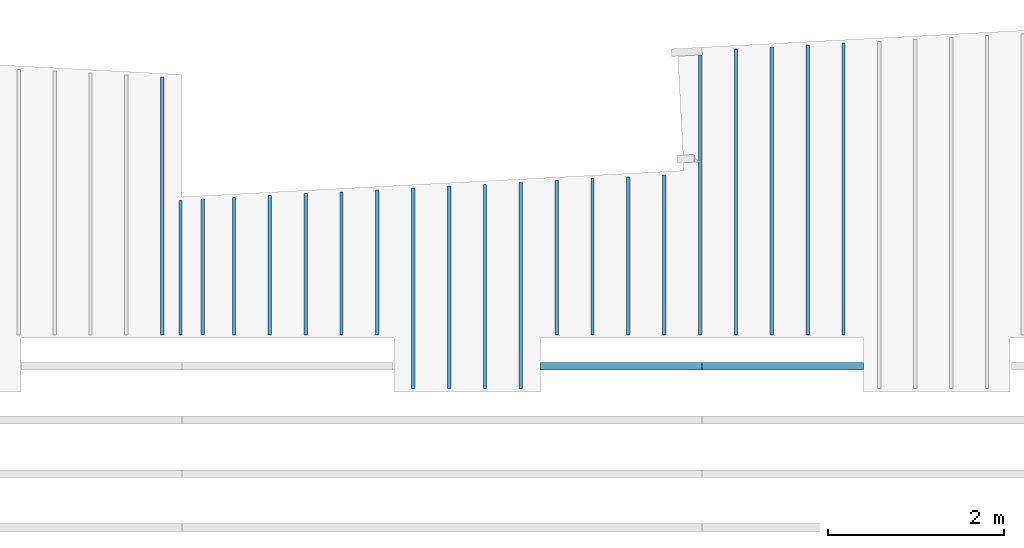
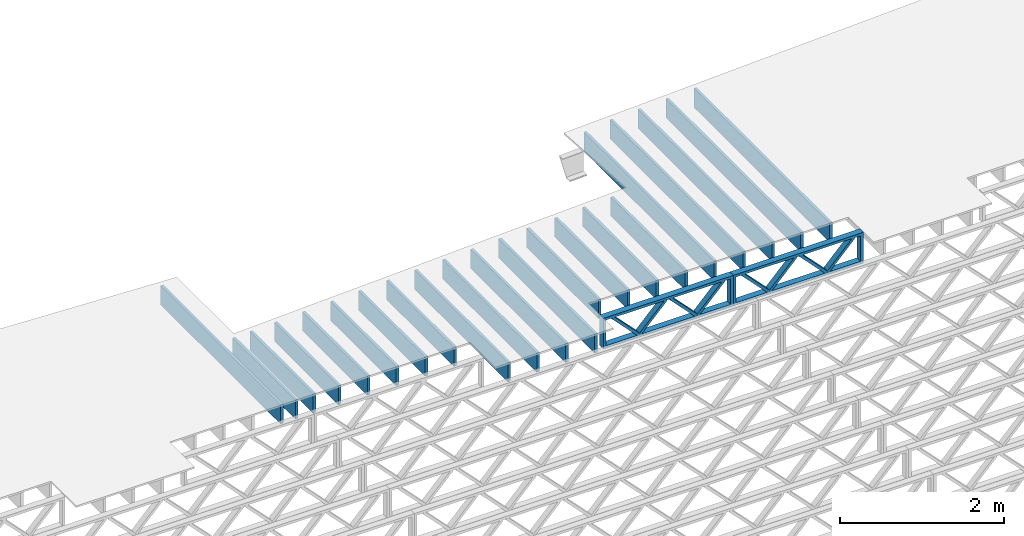
# One storey, part 5 of 12: 23 beams, 3 elements without a shape of their own.
"""IFC4 building model written with IfcOpenShell, lengths in feet."""

from ifc_helpers import new_model, entity, si_unit, converted_unit, derived_unit, direction, frame, frame_2d, origin, origin_2d_with_axis, place, context, subcontext, project, spatial, rectangle, extrude, source, transform, mapped, material, material_profile, profile_set, profile_usage, type_object, type_shapes, element, aggregate, save


model = new_model("IFC4")

# Units and contexts
model_context = context("Model", 3, precision=0.0001, world=origin(), true_north=direction((6.12303176911189e-17, 1.0)))
body_context = subcontext(model_context, "Body", "Model", "MODEL_VIEW")
ifc_project = project(units=[converted_unit("LENGTHUNIT", "FOOT", entity("IfcRatioMeasure", 0.3048), si_unit("LENGTHUNIT", "METRE"), dimensions=[1, 0, 0, 0, 0, 0, 0]), converted_unit("AREAUNIT", "SQUARE FOOT", entity("IfcRatioMeasure", 0.09290304), si_unit("AREAUNIT", "SQUARE_METRE"), dimensions=[2, 0, 0, 0, 0, 0, 0]), converted_unit("VOLUMEUNIT", "CUBIC FOOT", entity("IfcRatioMeasure", 0.028316846592), si_unit("VOLUMEUNIT", "CUBIC_METRE"), dimensions=[3, 0, 0, 0, 0, 0, 0]), converted_unit("PLANEANGLEUNIT", "DEGREE", entity("IfcRatioMeasure", 0.0174532925199433), si_unit("PLANEANGLEUNIT", "RADIAN"), dimensions=[0, 0, 0, 0, 0, 0, 0]), si_unit("MASSUNIT", "GRAM", prefix="KILO"), derived_unit("MASSDENSITYUNIT", [(si_unit("MASSUNIT", "GRAM", prefix="KILO"), 1), (si_unit("LENGTHUNIT", "METRE"), -3)]), derived_unit("MOMENTOFINERTIAUNIT", [(si_unit("LENGTHUNIT", "METRE"), 4)]), si_unit("TIMEUNIT", "SECOND"), si_unit("FREQUENCYUNIT", "HERTZ"), si_unit("THERMODYNAMICTEMPERATUREUNIT", "DEGREE_CELSIUS"), derived_unit("THERMALTRANSMITTANCEUNIT", [(si_unit("MASSUNIT", "GRAM", prefix="KILO"), 1), (si_unit("THERMODYNAMICTEMPERATUREUNIT", "KELVIN"), -1), (si_unit("TIMEUNIT", "SECOND"), -3)]), derived_unit("VOLUMETRICFLOWRATEUNIT", [(si_unit("LENGTHUNIT", "METRE"), 3), (si_unit("TIMEUNIT", "SECOND"), -1)]), si_unit("ELECTRICCURRENTUNIT", "AMPERE"), si_unit("ELECTRICVOLTAGEUNIT", "VOLT"), si_unit("POWERUNIT", "WATT"), si_unit("FORCEUNIT", "NEWTON"), si_unit("ILLUMINANCEUNIT", "LUX"), si_unit("LUMINOUSFLUXUNIT", "LUMEN"), si_unit("LUMINOUSINTENSITYUNIT", "CANDELA"), derived_unit("USERDEFINED", [(si_unit("MASSUNIT", "GRAM", prefix="KILO"), -1), (si_unit("LENGTHUNIT", "METRE"), -2), (si_unit("TIMEUNIT", "SECOND"), 3), (si_unit("LUMINOUSFLUXUNIT", "LUMEN"), 1)]), derived_unit("LINEARVELOCITYUNIT", [(si_unit("LENGTHUNIT", "METRE"), 1), (si_unit("TIMEUNIT", "SECOND"), -1)]), si_unit("PRESSUREUNIT", "PASCAL"), derived_unit("USERDEFINED", [(si_unit("LENGTHUNIT", "METRE"), -2), (si_unit("MASSUNIT", "GRAM", prefix="KILO"), 1), (si_unit("TIMEUNIT", "SECOND"), -2)]), derived_unit("LINEARFORCEUNIT", [(si_unit("MASSUNIT", "GRAM", prefix="KILO"), 1), (si_unit("LENGTHUNIT", "METRE"), 1), (si_unit("TIMEUNIT", "SECOND"), -2), (si_unit("LENGTHUNIT", "METRE"), -1)]), derived_unit("PLANARFORCEUNIT", [(si_unit("MASSUNIT", "GRAM", prefix="KILO"), 1), (si_unit("LENGTHUNIT", "METRE"), 1), (si_unit("TIMEUNIT", "SECOND"), -2), (si_unit("LENGTHUNIT", "METRE"), -2)])], contexts=[model_context])

# Site, building, storey
site_placement = place(None, origin())
site = spatial("IfcSite", under=ifc_project, at=site_placement, CompositionType="ELEMENT")
building_placement = place(site_placement, origin())
building = spatial("IfcBuilding", under=site, at=building_placement, CompositionType="ELEMENT")
storey_placement = place(building_placement, frame((0.0, 0.0, 21.46875)))
storey = spatial("IfcBuildingStorey", under=building, at=storey_placement, Name="3RD FLOOR", CompositionType="ELEMENT", Elevation=21.46875)

# Assembly, beam
assembly_1_placement = place(storey_placement, origin())
assembly_1 = element("IfcElementAssembly", 1, at=assembly_1_placement, inside=storey, Name="Structural Beam System:Structural Framing System", ObjectType="Structural Beam System:Structural Framing System", AssemblyPlace="NOTDEFINED", PredefinedType="BEAM_GRID")
ifc_material_1 = material(Name="WOOD TRUSS", Category="Materials")
ifc_material_profile_1 = material_profile(ifc_material_1, rectangle(XDim=1.73473973950632, YDim=0.125, at=frame_2d((-1.11022302462516e-16, 8.32667268468867e-17), x_axis=(1.0, 0.0))))
ifc_material_profile_2 = material_profile(ifc_material_1, rectangle(XDim=1.73473973950633, YDim=0.125, at=frame_2d((-1.11022302462516e-16, 8.32667268468867e-17), x_axis=(1.0, 0.0))))
ifc_material_profile_3 = material_profile(ifc_material_1, rectangle(XDim=1.73473973950632, YDim=0.125, at=frame_2d((-5.55111512312578e-17, 1.38777878078145e-16), x_axis=(1.0, 0.0))))
ifc_material_profile_4 = material_profile(ifc_material_1, rectangle(XDim=1.73473973950633, YDim=0.125, at=frame_2d((-1.11022302462516e-16, 8.32667268468867e-17), x_axis=(1.0, 0.0))))
ifc_material_profile_5 = material_profile(ifc_material_1, rectangle(XDim=1.73473973950632, YDim=0.125, at=frame_2d((-1.11022302462516e-16, 8.32667268468867e-17), x_axis=(1.0, 0.0))))
ifc_material_profile_6 = material_profile(ifc_material_1, rectangle(XDim=1.73473973950633, YDim=0.125, at=frame_2d((-2.77555756156289e-16, 3.05311331771918e-16), x_axis=(1.0, 0.0))))
ifc_material_profile_7 = material_profile(ifc_material_1, rectangle(XDim=1.73473973950632, YDim=0.124999999999999, at=frame_2d((-3.88578058618805e-16, -2.4980018054066e-16), x_axis=(1.0, 0.0))))
ifc_material_profile_8 = material_profile(ifc_material_1, rectangle(XDim=1.73473973950633, YDim=0.125, at=frame_2d((2.77555756156289e-16, -3.05311331771918e-16), x_axis=(1.0, 0.0))))
ifc_material_profile_9 = material_profile(ifc_material_1, rectangle(XDim=1.73473973950632, YDim=0.124999999999999, at=frame_2d((-1.11022302462516e-16, 8.32667268468867e-17), x_axis=(1.0, 0.0))))
ifc_material_profile_10 = material_profile(ifc_material_1, rectangle(XDim=1.73473973950633, YDim=0.125, at=origin_2d_with_axis()))
ifc_material_profile_11 = material_profile(ifc_material_1, rectangle(XDim=0.124999999999982, YDim=0.291666666666668, at=origin_2d_with_axis()))
ifc_material_profile_12 = material_profile(ifc_material_1, rectangle(XDim=0.124999999999932, YDim=0.291666666666664, at=origin_2d_with_axis()))
ifc_material_profile_13 = material_profile(ifc_material_1, rectangle(XDim=1.25000000000002, YDim=0.29166666666667, at=origin_2d_with_axis()))
ifc_material_profile_14 = material_profile(ifc_material_1, rectangle(XDim=1.25000000000004, YDim=0.291666666666667, at=origin_2d_with_axis()))
ifc_profile_set_1 = profile_set([ifc_material_profile_1, ifc_material_profile_2, ifc_material_profile_3, ifc_material_profile_4, ifc_material_profile_5, ifc_material_profile_6, ifc_material_profile_7, ifc_material_profile_8, ifc_material_profile_9, ifc_material_profile_10, ifc_material_profile_11, ifc_material_profile_12, ifc_material_profile_13, ifc_material_profile_14])
ifc_profile_usage_1 = profile_usage(ifc_profile_set_1, cardinal=8)
beam_type_1 = type_object("IfcBeamType", PredefinedType="BEAM", material=ifc_profile_set_1)
shared_shape_1 = source(origin(), body_context, "Body", "SweptSolid", [
    extrude(rectangle(XDim=1.73473973950632, YDim=0.125, at=frame_2d((0.0, 1.66533453693773e-16), x_axis=(1.0, 0.0))), frame((1.95847612494153, -0.145833333333334, 0.0), z_axis=(0.0, 1.0, 0.0), x_axis=(0.693383046997606, 0.0, 0.720569184836762)), (0.0, 0.0, 1.0), 0.291666666666667),
    extrude(rectangle(XDim=1.73473973950633, YDim=0.125, at=frame_2d((-5.55111512312578e-17, 8.32667268468867e-17), x_axis=(1.0, 0.0))), frame((0.708190251268258, -0.145833333333334, 0.0), z_axis=(0.0, 1.0, 0.0), x_axis=(0.69338304699761, 0.0, -0.720569184836758)), (0.0, 0.0, 1.0), 0.291666666666667),
    extrude(rectangle(XDim=1.73473973950632, YDim=0.125, at=frame_2d((0.0, 1.66533453693773e-16), x_axis=(1.0, 0.0))), frame((-0.708190251267602, -0.145833333333334, 0.0), z_axis=(0.0, 1.0, 0.0), x_axis=(0.693383046997606, 0.0, 0.720569184836762)), (0.0, 0.0, 1.0), 0.291666666666667),
    extrude(rectangle(XDim=1.73473973950633, YDim=0.125, at=frame_2d((-2.22044604925031e-16, 2.22044604925031e-16), x_axis=(1.0, 0.0))), frame((-1.95847612494087, -0.145833333333334, 0.0), z_axis=(0.0, 1.0, 0.0), x_axis=(0.69338304699761, 0.0, -0.720569184836758)), (0.0, 0.0, 1.0), 0.291666666666666),
    extrude(rectangle(XDim=0.124999999999982, YDim=0.291666666666668, at=origin_2d_with_axis()), frame((-2.99999985477115, 0.0, 0.687500000000054), z_axis=(1.0, 0.0, 0.0), x_axis=(0.0, 0.0, -1.0)), (0.0, 0.0, 1.0), 5.99999970954229),
    extrude(rectangle(XDim=0.124999999999932, YDim=0.291666666666664, at=origin_2d_with_axis()), frame((-2.99999985477093, 0.0, -0.687499999999984), z_axis=(1.0, 0.0, 0.0), x_axis=(0.0, 0.0, -1.0)), (0.0, 0.0, 1.0), 5.99999970954208),
    extrude(rectangle(XDim=1.25000000000002, YDim=0.29166666666667, at=origin_2d_with_axis()), frame((2.87499985477113, 0.0, 0.0), z_axis=(1.0, 0.0, 0.0), x_axis=(0.0, 0.0, -1.0)), (0.0, 0.0, 1.0), 0.12500000000002),
    extrude(rectangle(XDim=1.25000000000004, YDim=0.291666666666667, at=origin_2d_with_axis()), frame((-2.99999985477115, 0.0, 0.0), z_axis=(1.0, 0.0, 0.0), x_axis=(0.0, 0.0, -1.0)), (0.0, 0.0, 1.0), 0.125000000000023),
])
type_shapes(beam_type_1, [shared_shape_1])
beam_1_placement = place(assembly_1_placement, frame((-225.404826976829, 957.861934882651, -0.947916666666654)))
beam_1 = element("IfcBeam", 2, at=beam_1_placement, type_object=beam_type_1, material=ifc_profile_usage_1, PredefinedType="BEAM", context=body_context, shape_type="MappedRepresentation", body=[
    mapped(shared_shape_1, transform((0.0, 0.0, 0.0), scale=1.0)),
])
aggregate(assembly_1, [beam_1])

assembly_2_placement = place(storey_placement, origin())
assembly_2 = element("IfcElementAssembly", 3, at=assembly_2_placement, inside=storey, Name="Structural Beam System:Structural Framing System", ObjectType="Structural Beam System:Structural Framing System", AssemblyPlace="NOTDEFINED", PredefinedType="BEAM_GRID")
ifc_profile_usage_2 = profile_usage(ifc_profile_set_1, cardinal=8)
beam_type_2 = type_object("IfcBeamType", PredefinedType="BEAM", material=ifc_profile_set_1)
shared_shape_2 = source(origin(), body_context, "Body", "SweptSolid", [
    extrude(rectangle(XDim=1.73473973950632, YDim=0.125, at=frame_2d((0.0, 1.66533453693773e-16), x_axis=(1.0, 0.0))), frame((1.95847610985504, -0.145833333333334, 0.0), z_axis=(0.0, 1.0, 0.0), x_axis=(0.693383046997606, 0.0, 0.720569184836762)), (0.0, 0.0, 1.0), 0.291666666666667),
    extrude(rectangle(XDim=1.73473973950633, YDim=0.125, at=frame_2d((-5.55111512312578e-17, 8.32667268468867e-17), x_axis=(1.0, 0.0))), frame((0.708190236181772, -0.145833333333334, 0.0), z_axis=(0.0, 1.0, 0.0), x_axis=(0.69338304699761, 0.0, -0.720569184836758)), (0.0, 0.0, 1.0), 0.291666666666667),
    extrude(rectangle(XDim=1.73473973950632, YDim=0.125, at=frame_2d((0.0, 1.66533453693773e-16), x_axis=(1.0, 0.0))), frame((-0.708190236181118, -0.145833333333334, 0.0), z_axis=(0.0, 1.0, 0.0), x_axis=(0.693383046997606, 0.0, 0.720569184836762)), (0.0, 0.0, 1.0), 0.291666666666667),
    extrude(rectangle(XDim=1.73473973950633, YDim=0.125, at=frame_2d((-2.22044604925031e-16, 2.22044604925031e-16), x_axis=(1.0, 0.0))), frame((-1.95847610985439, -0.145833333333334, 0.0), z_axis=(0.0, 1.0, 0.0), x_axis=(0.69338304699761, 0.0, -0.720569184836758)), (0.0, 0.0, 1.0), 0.291666666666666),
    extrude(rectangle(XDim=0.124999999999982, YDim=0.291666666666668, at=origin_2d_with_axis()), frame((-2.99999983968466, 0.0, 0.687500000000054), z_axis=(1.0, 0.0, 0.0), x_axis=(0.0, 0.0, -1.0)), (0.0, 0.0, 1.0), 5.99999967936932),
    extrude(rectangle(XDim=0.124999999999932, YDim=0.291666666666664, at=origin_2d_with_axis()), frame((-2.99999983968445, 0.0, -0.687499999999984), z_axis=(1.0, 0.0, 0.0), x_axis=(0.0, 0.0, -1.0)), (0.0, 0.0, 1.0), 5.99999967936911),
    extrude(rectangle(XDim=1.25000000000002, YDim=0.29166666666667, at=origin_2d_with_axis()), frame((2.87499983968464, 0.0, 0.0), z_axis=(1.0, 0.0, 0.0), x_axis=(0.0, 0.0, -1.0)), (0.0, 0.0, 1.0), 0.12500000000002),
    extrude(rectangle(XDim=1.25000000000004, YDim=0.291666666666667, at=origin_2d_with_axis()), frame((-2.99999983968466, 0.0, 0.0), z_axis=(1.0, 0.0, 0.0), x_axis=(0.0, 0.0, -1.0)), (0.0, 0.0, 1.0), 0.125000000000023),
])
type_shapes(beam_type_2, [shared_shape_2])
beam_2_placement = place(assembly_2_placement, frame((-219.404827312476, 957.861934882651, -0.947916666666874), z_axis=(0.0, 0.0, 1.0), x_axis=(-1.0, 0.0, 0.0)))
beam_2 = element("IfcBeam", 4, at=beam_2_placement, type_object=beam_type_2, material=ifc_profile_usage_2, PredefinedType="BEAM", context=body_context, shape_type="MappedRepresentation", body=[
    mapped(shared_shape_2, transform((0.0, 0.0, 0.0), scale=1.0)),
])
aggregate(assembly_2, [beam_2])

# Assembly, beams
assembly_3_placement = place(storey_placement, origin())
assembly_3 = element("IfcElementAssembly", 5, at=assembly_3_placement, inside=storey, Name="Structural Beam System:Structural Framing System", ObjectType="Structural Beam System:Structural Framing System", AssemblyPlace="NOTDEFINED", PredefinedType="BEAM_GRID")
ifc_material_2 = material(Category="Materials")
ifc_material_profile_15 = material_profile(ifc_material_2, rectangle(XDim=0.9375, YDim=0.125000000000011, at=origin_2d_with_axis()))
ifc_profile_set_2 = profile_set([ifc_material_profile_15])
ifc_profile_usage_3 = profile_usage(ifc_profile_set_2, cardinal=8)
beam_type_3 = type_object("IfcBeamType", PredefinedType="BEAM", material=ifc_profile_set_2)
shared_shape_3 = source(origin(), body_context, "Body", "SweptSolid", [
    extrude(rectangle(XDim=0.9375, YDim=0.125000000000011, at=origin_2d_with_axis()), frame((-4.79624042361354, 0.0, 0.0), z_axis=(1.0, 0.0, 0.0), x_axis=(0.0, 0.0, -1.0)), (0.0, 0.0, 1.0), 9.59248084722708),
])
type_shapes(beam_type_3, [shared_shape_3])
beam_3_placement = place(assembly_3_placement, frame((-242.477622729298, 963.825759277043, -0.729166666666714), z_axis=(0.0, 0.0, 1.0), x_axis=(0.0, 1.0, 0.0)))
beam_3 = element("IfcBeam", 6, at=beam_3_placement, type_object=beam_type_3, material=ifc_profile_usage_3, PredefinedType="BEAM", context=body_context, shape_type="MappedRepresentation", body=[
    mapped(shared_shape_3, transform((0.0, 0.0, 0.0), scale=1.0)),
])
ifc_profile_usage_4 = profile_usage(ifc_profile_set_2, cardinal=8)
beam_type_4 = type_object("IfcBeamType", PredefinedType="BEAM", material=ifc_profile_set_2)
shared_shape_4 = source(origin(), body_context, "Body", "SweptSolid", [
    extrude(rectangle(XDim=0.9375, YDim=0.125000000000011, at=origin_2d_with_axis()), frame((-2.55387345689314, 0.0, 0.0), z_axis=(1.0, 0.0, 0.0), x_axis=(0.0, 0.0, -1.0)), (0.0, 0.0, 1.0), 5.10774691378629),
])
type_shapes(beam_type_4, [shared_shape_4])
beam_4_placement = place(assembly_3_placement, frame((-239.810956062631, 961.583391640318, -0.729166666666714), z_axis=(0.0, 0.0, 1.0), x_axis=(0.0, 1.0, 0.0)))
beam_4 = element("IfcBeam", 7, at=beam_4_placement, type_object=beam_type_4, material=ifc_profile_usage_4, PredefinedType="BEAM", context=body_context, shape_type="MappedRepresentation", body=[
    mapped(shared_shape_4, transform((0.0, 0.0, 0.0), scale=1.0)),
])
ifc_profile_usage_5 = profile_usage(ifc_profile_set_2, cardinal=8)
beam_type_5 = type_object("IfcBeamType", PredefinedType="BEAM", material=ifc_profile_set_2)
shared_shape_5 = source(origin(), body_context, "Body", "SweptSolid", [
    extrude(rectangle(XDim=0.9375, YDim=0.125000000000011, at=origin_2d_with_axis()), frame((-2.58881214391624, 0.0, 0.0), z_axis=(1.0, 0.0, 0.0), x_axis=(0.0, 0.0, -1.0)), (0.0, 0.0, 1.0), 5.17762428783249),
])
type_shapes(beam_type_5, [shared_shape_5])
beam_5_placement = place(assembly_3_placement, frame((-238.477622729298, 961.618329992338, -0.729166666666714), z_axis=(0.0, 0.0, 1.0), x_axis=(0.0, 1.0, 0.0)))
beam_5 = element("IfcBeam", 8, at=beam_5_placement, type_object=beam_type_5, material=ifc_profile_usage_5, PredefinedType="BEAM", context=body_context, shape_type="MappedRepresentation", body=[
    mapped(shared_shape_5, transform((0.0, 0.0, 0.0), scale=1.0)),
])
ifc_profile_usage_6 = profile_usage(ifc_profile_set_2, cardinal=8)
beam_type_6 = type_object("IfcBeamType", PredefinedType="BEAM", material=ifc_profile_set_2)
shared_shape_6 = source(origin(), body_context, "Body", "SweptSolid", [
    extrude(rectangle(XDim=0.9375, YDim=0.125000000000011, at=origin_2d_with_axis()), frame((-2.62375083093946, 0.0, 0.0), z_axis=(1.0, 0.0, 0.0), x_axis=(0.0, 0.0, -1.0)), (0.0, 0.0, 1.0), 5.24750166187891),
])
type_shapes(beam_type_6, [shared_shape_6])
beam_6_placement = place(assembly_3_placement, frame((-237.144289395965, 961.653268344359, -0.729166666666714), z_axis=(0.0, 0.0, 1.0), x_axis=(0.0, 1.0, 0.0)))
beam_6 = element("IfcBeam", 9, at=beam_6_placement, type_object=beam_type_6, material=ifc_profile_usage_6, PredefinedType="BEAM", context=body_context, shape_type="MappedRepresentation", body=[
    mapped(shared_shape_6, transform((0.0, 0.0, 0.0), scale=1.0)),
])
ifc_profile_usage_7 = profile_usage(ifc_profile_set_2, cardinal=8)
beam_type_7 = type_object("IfcBeamType", PredefinedType="BEAM", material=ifc_profile_set_2)
shared_shape_7 = source(origin(), body_context, "Body", "SweptSolid", [
    extrude(rectangle(XDim=0.9375, YDim=0.125000000000011, at=origin_2d_with_axis()), frame((-2.65868951796261, 0.0, 0.0), z_axis=(1.0, 0.0, 0.0), x_axis=(0.0, 0.0, -1.0)), (0.0, 0.0, 1.0), 5.31737903592523),
])
type_shapes(beam_type_7, [shared_shape_7])
beam_7_placement = place(assembly_3_placement, frame((-235.810956062631, 961.68820669638, -0.729166666666714), z_axis=(0.0, 0.0, 1.0), x_axis=(0.0, 1.0, 0.0)))
beam_7 = element("IfcBeam", 10, at=beam_7_placement, type_object=beam_type_7, material=ifc_profile_usage_7, PredefinedType="BEAM", context=body_context, shape_type="MappedRepresentation", body=[
    mapped(shared_shape_7, transform((0.0, 0.0, 0.0), scale=1.0)),
])
ifc_profile_usage_8 = profile_usage(ifc_profile_set_2, cardinal=8)
beam_type_8 = type_object("IfcBeamType", PredefinedType="BEAM", material=ifc_profile_set_2)
shared_shape_8 = source(origin(), body_context, "Body", "SweptSolid", [
    extrude(rectangle(XDim=0.9375, YDim=0.125000000000011, at=origin_2d_with_axis()), frame((-2.69362820498583, 0.0, 0.0), z_axis=(1.0, 0.0, 0.0), x_axis=(0.0, 0.0, -1.0)), (0.0, 0.0, 1.0), 5.38725640997166),
])
type_shapes(beam_type_8, [shared_shape_8])
beam_8_placement = place(assembly_3_placement, frame((-234.477622729298, 961.723145048401, -0.729166666666714), z_axis=(0.0, 0.0, 1.0), x_axis=(0.0, 1.0, 0.0)))
beam_8 = element("IfcBeam", 11, at=beam_8_placement, type_object=beam_type_8, material=ifc_profile_usage_8, PredefinedType="BEAM", context=body_context, shape_type="MappedRepresentation", body=[
    mapped(shared_shape_8, transform((0.0, 0.0, 0.0), scale=1.0)),
])
ifc_profile_usage_9 = profile_usage(ifc_profile_set_2, cardinal=8)
beam_type_9 = type_object("IfcBeamType", PredefinedType="BEAM", material=ifc_profile_set_2)
shared_shape_9 = source(origin(), body_context, "Body", "SweptSolid", [
    extrude(rectangle(XDim=0.9375, YDim=0.125000000000011, at=origin_2d_with_axis()), frame((-3.72856703576554, 0.0, 0.0), z_axis=(1.0, 0.0, 0.0), x_axis=(0.0, 0.0, -1.0)), (0.0, 0.0, 1.0), 7.45713407153107),
])
type_shapes(beam_type_9, [shared_shape_9])
beam_9_placement = place(assembly_3_placement, frame((-233.144289395965, 960.758083256665, -0.729166666666714), z_axis=(0.0, 0.0, 1.0), x_axis=(0.0, 1.0, 0.0)))
beam_9 = element("IfcBeam", 12, at=beam_9_placement, type_object=beam_type_9, material=ifc_profile_usage_9, PredefinedType="BEAM", context=body_context, shape_type="MappedRepresentation", body=[
    mapped(shared_shape_9, transform((0.0, 0.0, 0.0), scale=1.0)),
])
ifc_profile_usage_10 = profile_usage(ifc_profile_set_2, cardinal=8)
beam_type_10 = type_object("IfcBeamType", PredefinedType="BEAM", material=ifc_profile_set_2)
shared_shape_10 = source(origin(), body_context, "Body", "SweptSolid", [
    extrude(rectangle(XDim=0.9375, YDim=0.125000000000011, at=origin_2d_with_axis()), frame((-3.76350555528745, 0.0, 0.0), z_axis=(1.0, 0.0, 0.0), x_axis=(0.0, 0.0, -1.0)), (0.0, 0.0, 1.0), 7.5270111105749),
])
type_shapes(beam_type_10, [shared_shape_10])
beam_10_placement = place(assembly_3_placement, frame((-231.810956062631, 960.793021776187, -0.729166666666714), z_axis=(0.0, 0.0, 1.0), x_axis=(0.0, 1.0, 0.0)))
beam_10 = element("IfcBeam", 13, at=beam_10_placement, type_object=beam_type_10, material=ifc_profile_usage_10, PredefinedType="BEAM", context=body_context, shape_type="MappedRepresentation", body=[
    mapped(shared_shape_10, transform((0.0, 0.0, 0.0), scale=1.0)),
])
ifc_profile_usage_11 = profile_usage(ifc_profile_set_2, cardinal=8)
beam_type_11 = type_object("IfcBeamType", PredefinedType="BEAM", material=ifc_profile_set_2)
shared_shape_11 = source(origin(), body_context, "Body", "SweptSolid", [
    extrude(rectangle(XDim=0.9375, YDim=0.125000000000011, at=origin_2d_with_axis()), frame((-3.79844407480942, 0.0, 0.0), z_axis=(1.0, 0.0, 0.0), x_axis=(0.0, 0.0, -1.0)), (0.0, 0.0, 1.0), 7.59688814961885),
])
type_shapes(beam_type_11, [shared_shape_11])
beam_11_placement = place(assembly_3_placement, frame((-230.477622729298, 960.827960295709, -0.729166666666714), z_axis=(0.0, 0.0, 1.0), x_axis=(0.0, 1.0, 0.0)))
beam_11 = element("IfcBeam", 14, at=beam_11_placement, type_object=beam_type_11, material=ifc_profile_usage_11, PredefinedType="BEAM", context=body_context, shape_type="MappedRepresentation", body=[
    mapped(shared_shape_11, transform((0.0, 0.0, 0.0), scale=1.0)),
])
ifc_profile_usage_12 = profile_usage(ifc_profile_set_2, cardinal=8)
beam_type_12 = type_object("IfcBeamType", PredefinedType="BEAM", material=ifc_profile_set_2)
shared_shape_12 = source(origin(), body_context, "Body", "SweptSolid", [
    extrude(rectangle(XDim=0.9375, YDim=0.125000000000011, at=origin_2d_with_axis()), frame((-3.83338259433134, 0.0, 0.0), z_axis=(1.0, 0.0, 0.0), x_axis=(0.0, 0.0, -1.0)), (0.0, 0.0, 1.0), 7.66676518866268),
])
type_shapes(beam_type_12, [shared_shape_12])
beam_12_placement = place(assembly_3_placement, frame((-229.144289395965, 960.862898815231, -0.729166666666714), z_axis=(0.0, 0.0, 1.0), x_axis=(0.0, 1.0, 0.0)))
beam_12 = element("IfcBeam", 15, at=beam_12_placement, type_object=beam_type_12, material=ifc_profile_usage_12, PredefinedType="BEAM", context=body_context, shape_type="MappedRepresentation", body=[
    mapped(shared_shape_12, transform((0.0, 0.0, 0.0), scale=1.0)),
])
ifc_profile_usage_13 = profile_usage(ifc_profile_set_2, cardinal=8)
beam_type_13 = type_object("IfcBeamType", PredefinedType="BEAM", material=ifc_profile_set_2)
shared_shape_13 = source(origin(), body_context, "Body", "SweptSolid", [
    extrude(rectangle(XDim=0.9375, YDim=0.125000000000011, at=origin_2d_with_axis()), frame((-2.86831945862667, 0.0, 0.0), z_axis=(1.0, 0.0, 0.0), x_axis=(0.0, 0.0, -1.0)), (0.0, 0.0, 1.0), 5.73663891725334),
])
type_shapes(beam_type_13, [shared_shape_13])
beam_13_placement = place(assembly_3_placement, frame((-227.810956062631, 961.897838989979, -0.729166666666714), z_axis=(0.0, 0.0, 1.0), x_axis=(0.0, 1.0, 0.0)))
beam_13 = element("IfcBeam", 16, at=beam_13_placement, type_object=beam_type_13, material=ifc_profile_usage_13, PredefinedType="BEAM", context=body_context, shape_type="MappedRepresentation", body=[
    mapped(shared_shape_13, transform((0.0, 0.0, 0.0), scale=1.0)),
])
ifc_profile_usage_14 = profile_usage(ifc_profile_set_2, cardinal=8)
beam_type_14 = type_object("IfcBeamType", PredefinedType="BEAM", material=ifc_profile_set_2)
shared_shape_14 = source(origin(), body_context, "Body", "SweptSolid", [
    extrude(rectangle(XDim=0.9375, YDim=0.125000000000011, at=origin_2d_with_axis()), frame((-2.90325814564983, 0.0, 0.0), z_axis=(1.0, 0.0, 0.0), x_axis=(0.0, 0.0, -1.0)), (0.0, 0.0, 1.0), 5.80651629129966),
])
type_shapes(beam_type_14, [shared_shape_14])
beam_14_placement = place(assembly_3_placement, frame((-226.477622729298, 961.932777342, -0.729166666666714), z_axis=(0.0, 0.0, 1.0), x_axis=(0.0, 1.0, 0.0)))
beam_14 = element("IfcBeam", 17, at=beam_14_placement, type_object=beam_type_14, material=ifc_profile_usage_14, PredefinedType="BEAM", context=body_context, shape_type="MappedRepresentation", body=[
    mapped(shared_shape_14, transform((0.0, 0.0, 0.0), scale=1.0)),
])
ifc_profile_usage_15 = profile_usage(ifc_profile_set_2, cardinal=8)
beam_type_15 = type_object("IfcBeamType", PredefinedType="BEAM", material=ifc_profile_set_2)
shared_shape_15 = source(origin(), body_context, "Body", "SweptSolid", [
    extrude(rectangle(XDim=0.9375, YDim=0.125000000000011, at=origin_2d_with_axis()), frame((-2.93819683267299, 0.0, 0.0), z_axis=(1.0, 0.0, 0.0), x_axis=(0.0, 0.0, -1.0)), (0.0, 0.0, 1.0), 5.87639366534597),
])
type_shapes(beam_type_15, [shared_shape_15])
beam_15_placement = place(assembly_3_placement, frame((-225.144289395965, 961.967715694021, -0.729166666666714), z_axis=(0.0, 0.0, 1.0), x_axis=(0.0, 1.0, 0.0)))
beam_15 = element("IfcBeam", 18, at=beam_15_placement, type_object=beam_type_15, material=ifc_profile_usage_15, PredefinedType="BEAM", context=body_context, shape_type="MappedRepresentation", body=[
    mapped(shared_shape_15, transform((0.0, 0.0, 0.0), scale=1.0)),
])
ifc_profile_usage_16 = profile_usage(ifc_profile_set_2, cardinal=8)
beam_type_16 = type_object("IfcBeamType", PredefinedType="BEAM", material=ifc_profile_set_2)
shared_shape_16 = source(origin(), body_context, "Body", "SweptSolid", [
    extrude(rectangle(XDim=0.9375, YDim=0.125000000000011, at=origin_2d_with_axis()), frame((-2.97313544216473, 0.0, 0.0), z_axis=(1.0, 0.0, 0.0), x_axis=(0.0, 0.0, -1.0)), (0.0, 0.0, 1.0), 5.94627088432946),
])
type_shapes(beam_type_16, [shared_shape_16])
beam_16_placement = place(assembly_3_placement, frame((-223.810956052701, 962.002653967741, -0.729166666666714), z_axis=(0.0, 0.0, 1.0), x_axis=(0.0, 1.0, 0.0)))
beam_16 = element("IfcBeam", 19, at=beam_16_placement, type_object=beam_type_16, material=ifc_profile_usage_16, PredefinedType="BEAM", context=body_context, shape_type="MappedRepresentation", body=[
    mapped(shared_shape_16, transform((0.0, 0.0, 0.0), scale=1.0)),
])
ifc_profile_usage_17 = profile_usage(ifc_profile_set_2, cardinal=8)
beam_type_17 = type_object("IfcBeamType", PredefinedType="BEAM", material=ifc_profile_set_2)
shared_shape_17 = source(origin(), body_context, "Body", "SweptSolid", [
    extrude(rectangle(XDim=0.9375, YDim=0.125000000000011, at=origin_2d_with_axis()), frame((-5.31173131535462, 0.0, 0.0), z_axis=(1.0, 0.0, 0.0), x_axis=(0.0, 0.0, -1.0)), (0.0, 0.0, 1.0), 10.4022217638584),
])
type_shapes(beam_type_17, [shared_shape_17])
beam_17_placement = place(assembly_3_placement, frame((-222.477622719368, 964.34124950669, -0.729166666666714), z_axis=(0.0, 0.0, 1.0), x_axis=(0.0, 1.0, 0.0)))
beam_17 = element("IfcBeam", 20, at=beam_17_placement, type_object=beam_type_17, material=ifc_profile_usage_17, PredefinedType="BEAM", context=body_context, shape_type="MappedRepresentation", body=[
    mapped(shared_shape_17, transform((0.0, 0.0, 0.0), scale=1.0)),
])
ifc_profile_usage_18 = profile_usage(ifc_profile_set_2, cardinal=8)
beam_type_18 = type_object("IfcBeamType", PredefinedType="BEAM", material=ifc_profile_set_2)
shared_shape_18 = source(origin(), body_context, "Body", "SweptSolid", [
    extrude(rectangle(XDim=0.9375, YDim=0.125000000000011, at=origin_2d_with_axis()), frame((-5.31696262266729, 0.0, 0.0), z_axis=(1.0, 0.0, 0.0), x_axis=(0.0, 0.0, -1.0)), (0.0, 0.0, 1.0), 10.6339252453346),
])
type_shapes(beam_type_18, [shared_shape_18])
beam_18_placement = place(assembly_3_placement, frame((-221.144289386034, 964.346480478709, -0.729166666666714), z_axis=(0.0, 0.0, 1.0), x_axis=(0.0, 1.0, 0.0)))
beam_18 = element("IfcBeam", 21, at=beam_18_placement, type_object=beam_type_18, material=ifc_profile_usage_18, PredefinedType="BEAM", context=body_context, shape_type="MappedRepresentation", body=[
    mapped(shared_shape_18, transform((0.0, 0.0, 0.0), scale=1.0)),
])
ifc_profile_usage_19 = profile_usage(ifc_profile_set_2, cardinal=8)
beam_type_19 = type_object("IfcBeamType", PredefinedType="BEAM", material=ifc_profile_set_2)
shared_shape_19 = source(origin(), body_context, "Body", "SweptSolid", [
    extrude(rectangle(XDim=0.9375, YDim=0.125000000000011, at=origin_2d_with_axis()), frame((-5.35190130957301, 0.0, 0.0), z_axis=(1.0, 0.0, 0.0), x_axis=(0.0, 0.0, -1.0)), (0.0, 0.0, 1.0), 10.703802619146),
])
type_shapes(beam_type_19, [shared_shape_19])
beam_19_placement = place(assembly_3_placement, frame((-219.810956052701, 964.381418830847, -0.729166666666714), z_axis=(0.0, 0.0, 1.0), x_axis=(0.0, 1.0, 0.0)))
beam_19 = element("IfcBeam", 22, at=beam_19_placement, type_object=beam_type_19, material=ifc_profile_usage_19, PredefinedType="BEAM", context=body_context, shape_type="MappedRepresentation", body=[
    mapped(shared_shape_19, transform((0.0, 0.0, 0.0), scale=1.0)),
])
ifc_profile_usage_20 = profile_usage(ifc_profile_set_2, cardinal=8)
beam_type_20 = type_object("IfcBeamType", PredefinedType="BEAM", material=ifc_profile_set_2)
shared_shape_20 = source(origin(), body_context, "Body", "SweptSolid", [
    extrude(rectangle(XDim=0.9375, YDim=0.125000000000011, at=origin_2d_with_axis()), frame((-5.38683999647867, 0.0, 0.0), z_axis=(1.0, 0.0, 0.0), x_axis=(0.0, 0.0, -1.0)), (0.0, 0.0, 1.0), 10.7736799929573),
])
type_shapes(beam_type_20, [shared_shape_20])
beam_20_placement = place(assembly_3_placement, frame((-218.477622719368, 964.416357182985, -0.729166666666714), z_axis=(0.0, 0.0, 1.0), x_axis=(0.0, 1.0, 0.0)))
beam_20 = element("IfcBeam", 23, at=beam_20_placement, type_object=beam_type_20, material=ifc_profile_usage_20, PredefinedType="BEAM", context=body_context, shape_type="MappedRepresentation", body=[
    mapped(shared_shape_20, transform((0.0, 0.0, 0.0), scale=1.0)),
])
ifc_profile_usage_21 = profile_usage(ifc_profile_set_2, cardinal=8)
beam_type_21 = type_object("IfcBeamType", PredefinedType="BEAM", material=ifc_profile_set_2)
shared_shape_21 = source(origin(), body_context, "Body", "SweptSolid", [
    extrude(rectangle(XDim=0.9375, YDim=0.125000000000011, at=origin_2d_with_axis()), frame((-5.42177868338433, 0.0, 0.0), z_axis=(1.0, 0.0, 0.0), x_axis=(0.0, 0.0, -1.0)), (0.0, 0.0, 1.0), 10.8435573667687),
])
type_shapes(beam_type_21, [shared_shape_21])
beam_21_placement = place(assembly_3_placement, frame((-217.144289386034, 964.451295535123, -0.729166666666714), z_axis=(0.0, 0.0, 1.0), x_axis=(0.0, 1.0, 0.0)))
beam_21 = element("IfcBeam", 24, at=beam_21_placement, type_object=beam_type_21, material=ifc_profile_usage_21, PredefinedType="BEAM", context=body_context, shape_type="MappedRepresentation", body=[
    mapped(shared_shape_21, transform((0.0, 0.0, 0.0), scale=1.0)),
])
aggregate(assembly_3, [beam_3, beam_4, beam_5, beam_6, beam_7, beam_8, beam_9, beam_10, beam_11, beam_12, beam_13, beam_14, beam_15, beam_16, beam_17, beam_18, beam_19, beam_20, beam_21])

# Beams
ifc_profile_usage_22 = profile_usage(ifc_profile_set_2, cardinal=8)
beam_type_22 = type_object("IfcBeamType", PredefinedType="BEAM", material=ifc_profile_set_2)
shared_shape_22 = source(origin(), body_context, "Body", "SweptSolid", [
    extrude(rectangle(XDim=0.9375, YDim=0.125000000000011, at=origin_2d_with_axis()), frame((-2.50173504911743, 0.0, 0.0), z_axis=(1.0, 0.0, 0.0), x_axis=(0.0, 0.0, -1.0)), (0.0, 0.0, 1.0), 5.00347009823486),
])
type_shapes(beam_type_22, [shared_shape_22])
beam_22_placement = place(storey_placement, frame((-241.800660485556, 961.531253902547, -0.729166666666714), z_axis=(0.0, 0.0, 1.0), x_axis=(0.0, 1.0, 0.0)))
element("IfcBeam", 25, at=beam_22_placement, inside=storey, type_object=beam_type_22, material=ifc_profile_usage_22, PredefinedType="BEAM", context=body_context, shape_type="MappedRepresentation", body=[
    mapped(shared_shape_22, transform((0.0, 0.0, 0.0), scale=1.0)),
])
ifc_profile_usage_23 = profile_usage(ifc_profile_set_2, cardinal=8)
beam_type_23 = type_object("IfcBeamType", PredefinedType="BEAM", material=ifc_profile_set_2)
shared_shape_23 = source(origin(), body_context, "Body", "SweptSolid", [
    extrude(rectangle(XDim=0.9375, YDim=0.125000000000011, at=origin_2d_with_axis()), frame((-2.51893476986993, 0.0, 0.0), z_axis=(1.0, 0.0, 0.0), x_axis=(0.0, 0.0, -1.0)), (0.0, 0.0, 1.0), 5.03786953973986),
])
type_shapes(beam_type_23, [shared_shape_23])
beam_23_placement = place(storey_placement, frame((-240.972536712724, 961.557454465011, -0.729166666666714), z_axis=(0.0, 0.0, 1.0), x_axis=(0.0, 1.0, 0.0)))
element("IfcBeam", 26, at=beam_23_placement, inside=storey, type_object=beam_type_23, material=ifc_profile_usage_23, PredefinedType="BEAM", context=body_context, shape_type="MappedRepresentation", body=[
    mapped(shared_shape_23, transform((0.0, 0.0, 0.0), scale=1.0)),
])

save(model, "model.ifc")
